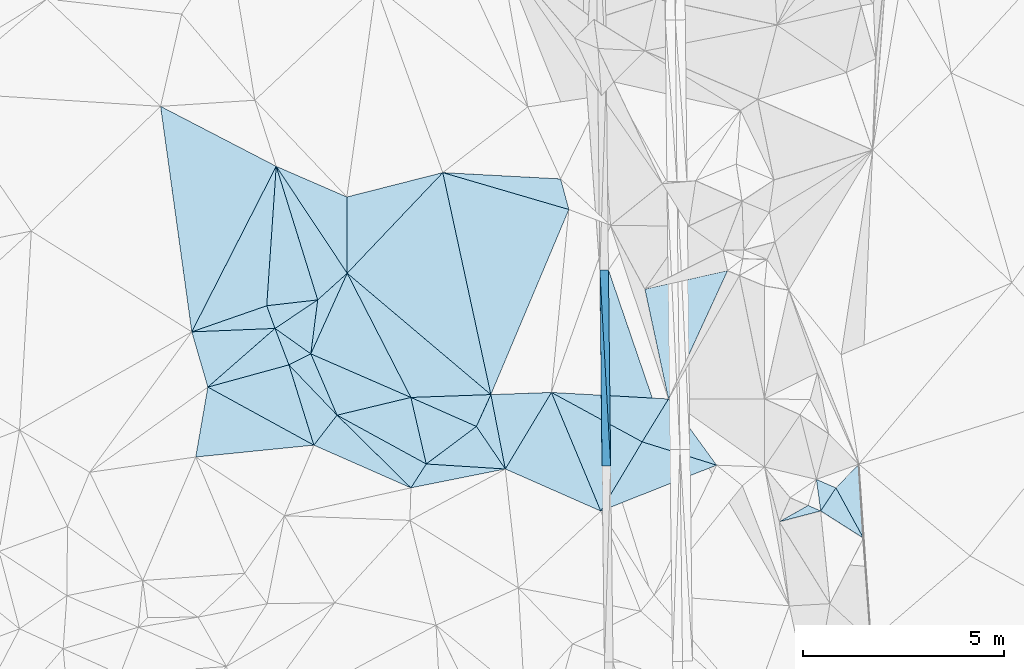
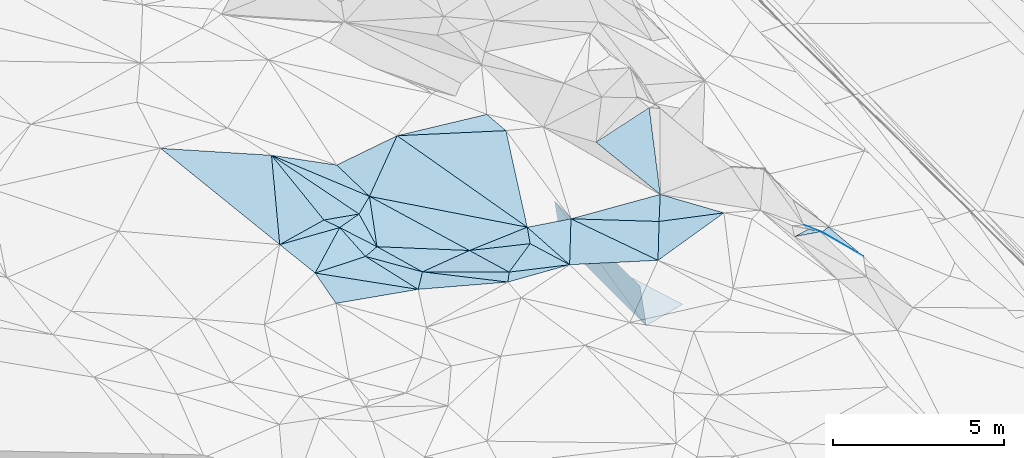
# One storey, part 13 of 275: 45 plates.
"""IFC2X3 building model written with IfcOpenShell, lengths in millimetres."""

from ifc_helpers import new_model, si_unit, frame, origin_with_axes, place, context, subcontext, project, spatial, polyline, outline, extrude, material, type_object, element, save


model = new_model("IFC2X3")

# Units and contexts
model_context = context("Model", 3, precision=1e-05, world=origin_with_axes())
body_context = subcontext(model_context, "Body", "Model", "MODEL_VIEW")
ifc_project = project(units=[si_unit("LENGTHUNIT", "METRE", prefix="MILLI"), si_unit("AREAUNIT", "SQUARE_METRE"), si_unit("VOLUMEUNIT", "CUBIC_METRE"), si_unit("MASSUNIT", "GRAM", prefix="KILO"), si_unit("TIMEUNIT", "SECOND"), si_unit("PLANEANGLEUNIT", "RADIAN"), si_unit("SOLIDANGLEUNIT", "STERADIAN"), si_unit("THERMODYNAMICTEMPERATUREUNIT", "DEGREE_CELSIUS"), si_unit("LUMINOUSINTENSITYUNIT", "LUMEN")], contexts=[model_context])

# Site, building, storey
site_placement = place(None, origin_with_axes())
site = spatial("IfcSite", under=ifc_project, at=site_placement, CompositionType="ELEMENT")
building_placement = place(site_placement, origin_with_axes())
building = spatial("IfcBuilding", under=site, at=building_placement, Name="Undefined", CompositionType="ELEMENT")
storey_placement = place(building_placement, origin_with_axes())
storey = spatial("IfcBuildingStorey", under=building, at=storey_placement, Name="Undefined", CompositionType="ELEMENT", Elevation=0.0)

# Plates
ifc_material = material()
plate_type_1 = type_object("IfcPlateType", PredefinedType="NOTDEFINED")
plate_1_placement = place(storey_placement, frame((-110130.239028706, 11119.0053173972, 45089.5004675806), z_axis=(0.0053338737207397, -0.0442314183425062, -0.999007072759018), x_axis=(-0.915008238746431, 0.402794931662664, -0.0227192881276)))
element("IfcPlate", 1, at=plate_1_placement, inside=storey, type_object=plate_type_1, material=ifc_material, Name="00", context=body_context, shape_type="SweptSolid", body=[
    extrude(outline(polyline([(0.0, 0.0), (2640.92797851563, 1.64291122928262e-08), (2414.45434570313, 917.065856933594), (0.0, 0.0)])), frame((-8.85201319254618e-08, 2.18876761149539e-07, -0.5000001331573), z_axis=(0.0, 0.0, 1.0), x_axis=(1.0, 0.0, 0.0)), (0.0, 0.0, 1.0), 1.0),
])
plate_type_2 = type_object("IfcPlateType", PredefinedType="NOTDEFINED")
plate_2_placement = place(storey_placement, frame((-105156.932146146, 11664.6181601126, 41451.6762923325), z_axis=(-0.9899146329082, -0.00833179240582941, -0.141419944808111), x_axis=(-0.141410880012788, -0.00167020099085582, 0.989949581262934)))
element("IfcPlate", 2, at=plate_2_placement, inside=storey, type_object=plate_type_2, material=ifc_material, Name="00_PR", context=body_context, shape_type="SweptSolid", body=[
    extrude(outline(polyline([(0.0, 0.0), (1515.22863769531, 2.66300048679113e-09), (1616.09216308594, 4885.20556640625), (0.0, 0.0)])), frame((-8.85201319254618e-08, 2.18876761149539e-07, -0.5000001331573), z_axis=(0.0, 0.0, 1.0), x_axis=(1.0, 0.0, 0.0)), (0.0, 0.0, 1.0), 1.0),
])
plate_3_placement = place(storey_placement, frame((-105426.912494542, 16546.9483812212, 43053.8472911902), z_axis=(-0.9899146329082, -0.00833179240582941, -0.141419944808111), x_axis=(0.141412524027666, 0.00155547700603329, -0.989949533329557)))
element("IfcPlate", 3, at=plate_3_placement, inside=storey, type_object=plate_type_2, material=ifc_material, Name="00_PR", context=body_context, shape_type="SweptSolid", body=[
    extrude(outline(polyline([(0.0, 0.0), (1515.22875976563, -2.92493496090174e-09), (1616.65270996094, 4885.0205078125), (0.0, 0.0)])), frame((-8.85201319254618e-08, 2.18876761149539e-07, -0.5000001331573), z_axis=(0.0, 0.0, 1.0), x_axis=(1.0, 0.0, 0.0)), (0.0, 0.0, 1.0), 1.0),
])
plate_type_3 = type_object("IfcPlateType", PredefinedType="NOTDEFINED")
plate_4_placement = place(storey_placement, frame((-105156.437303955, 11664.6327785077, 41451.2471111526), z_axis=(-0.000228104128301301, 0.0209094153861433, -0.999781348254065), x_axis=(-0.0114013891009877, 0.999716336142684, 0.0209106569963038)))
element("IfcPlate", 4, at=plate_4_placement, inside=storey, type_object=plate_type_3, material=ifc_material, Name="00_PR", context=body_context, shape_type="SweptSolid", body=[
    extrude(outline(polyline([(0.0, 0.0), (4886.0732421875, 1.48429535329342e-09), (393.802703857422, 1479.8544921875), (0.0, 0.0)])), frame((-8.85201319254618e-08, 2.18876761149539e-07, -0.5000001331573), z_axis=(0.0, 0.0, 1.0), x_axis=(1.0, 0.0, 0.0)), (0.0, 0.0, 1.0), 1.0),
])
plate_type_4 = type_object("IfcPlateType", PredefinedType="NOTDEFINED")
plate_5_placement = place(storey_placement, frame((-98862.6700222759, 9868.25020849909, 42819.6402361128), z_axis=(-0.674029591261077, -0.167293435981402, -0.719511651317726), x_axis=(-0.702389133978504, 0.446780994797911, 0.554108515686519)))
element("IfcPlate", 5, at=plate_5_placement, inside=storey, type_object=plate_type_4, material=ifc_material, Name="00", context=body_context, shape_type="SweptSolid", body=[
    extrude(outline(polyline([(0.0, 0.0), (1515.94860839844, -7.26140569895506e-09), (1232.89147949219, 795.7880859375), (0.0, 0.0)])), frame((-8.85201319254618e-08, 2.18876761149539e-07, -0.5000001331573), z_axis=(0.0, 0.0, 1.0), x_axis=(1.0, 0.0, 0.0)), (0.0, 0.0, 1.0), 1.0),
])
plate_type_5 = type_object("IfcPlateType", PredefinedType="NOTDEFINED")
plate_6_placement = place(storey_placement, frame((-106632.78345996, 13496.2431782016, 44679.5020463285), z_axis=(-0.0127394409879164, 0.0898641557380357, -0.99587255216559), x_axis=(0.998284841746694, -0.0557712403243994, -0.017802906826004)))
element("IfcPlate", 6, at=plate_6_placement, inside=storey, type_object=plate_type_5, material=ifc_material, Name="00", context=body_context, shape_type="SweptSolid", body=[
    extrude(outline(polyline([(0.0, 0.0), (2920.87133789063, 3.25962901115417e-09), (2328.06225585938, 1107.35107421875), (0.0, 0.0)])), frame((-8.85201319254618e-08, 2.18876761149539e-07, -0.5000001331573), z_axis=(0.0, 0.0, 1.0), x_axis=(1.0, 0.0, 0.0)), (0.0, 0.0, 1.0), 1.0),
])
plate_type_6 = type_object("IfcPlateType", PredefinedType="NOTDEFINED")
plate_7_placement = place(storey_placement, frame((-100033.494880504, 11329.5507361233, 43459.6153615499), z_axis=(-0.577058489481053, -0.274304851139707, -0.769259610508097), x_axis=(0.805127796024998, -0.349087637852481, -0.479486238766562)))
element("IfcPlate", 7, at=plate_7_placement, inside=storey, type_object=plate_type_6, material=ifc_material, Name="00", context=body_context, shape_type="SweptSolid", body=[
    extrude(outline(polyline([(0.0, 0.0), (604.814025878906, 2.53930920735002e-09), (263.221405029297, 772.472961425781), (0.0, 0.0)])), frame((-8.85201319254618e-08, 2.18876761149539e-07, -0.5000001331573), z_axis=(0.0, 0.0, 1.0), x_axis=(1.0, 0.0, 0.0)), (0.0, 0.0, 1.0), 1.0),
])
plate_type_7 = type_object("IfcPlateType", PredefinedType="NOTDEFINED")
plate_8_placement = place(storey_placement, frame((-115587.257552117, 15004.294891326, 45979.5018099799), z_axis=(-0.0805167497092928, -0.029362886133653, -0.996320668225925), x_axis=(0.940863941063242, 0.327767364665611, -0.0856948018674758)))
element("IfcPlate", 8, at=plate_8_placement, inside=storey, type_object=plate_type_7, material=ifc_material, Name="00", context=body_context, shape_type="SweptSolid", body=[
    extrude(outline(polyline([(0.0, 0.0), (1983.78430175781, -4.81668394058943e-09), (1992.45458984375, 601.269348144531), (0.0, 0.0)])), frame((-8.85201319254618e-08, 2.18876761149539e-07, -0.5000001331573), z_axis=(0.0, 0.0, 1.0), x_axis=(1.0, 0.0, 0.0)), (0.0, 0.0, 1.0), 1.0),
])
plate_type_8 = type_object("IfcPlateType", PredefinedType="NOTDEFINED")
plate_9_placement = place(storey_placement, frame((-112622.586519922, 14456.4102395896, 45199.5303135655), z_axis=(-0.250333388708989, 0.234567258158081, -0.939314322204061), x_axis=(0.123552824374264, 0.97001328402487, 0.209305825060913)))
element("IfcPlate", 9, at=plate_9_placement, inside=storey, type_object=plate_type_8, material=ifc_material, Name="00", context=body_context, shape_type="SweptSolid", body=[
    extrude(outline(polyline([(0.0, 0.0), (1385.53234863281, -6.98491930961609e-10), (2113.7001953125, 671.097412109375), (0.0, 0.0)])), frame((-8.85201319254618e-08, 2.18876761149539e-07, -0.5000001331573), z_axis=(0.0, 0.0, 1.0), x_axis=(1.0, 0.0, 0.0)), (0.0, 0.0, 1.0), 1.0),
])
plate_type_9 = type_object("IfcPlateType", PredefinedType="NOTDEFINED")
plate_10_placement = place(storey_placement, frame((-108499.612225928, 12648.9768326386, 44959.5011038815), z_axis=(0.0452481400221768, -0.0497726324744985, -0.997735080510399), x_axis=(-0.800536270796005, -0.599250012611244, -0.00641104714139014)))
element("IfcPlate", 10, at=plate_10_placement, inside=storey, type_object=plate_type_9, material=ifc_material, Name="00", context=body_context, shape_type="SweptSolid", body=[
    extrude(outline(polyline([(0.0, 0.0), (1559.80773925781, -7.7270669862628e-09), (873.889770507813, 1559.10766601563), (0.0, 0.0)])), frame((-8.85201319254618e-08, 2.18876761149539e-07, -0.5000001331573), z_axis=(0.0, 0.0, 1.0), x_axis=(1.0, 0.0, 0.0)), (0.0, 0.0, 1.0), 1.0),
])
plate_type_10 = type_object("IfcPlateType", PredefinedType="NOTDEFINED")
plate_11_placement = place(storey_placement, frame((-110130.873654558, 13371.0476788395, 44849.5010672645), z_axis=(0.0467587126944791, -0.0463743566773498, -0.997829164651904), x_axis=(0.998342954458697, 0.035710621637995, 0.0451231291568718)))
element("IfcPlate", 11, at=plate_11_placement, inside=storey, type_object=plate_type_10, material=ifc_material, Name="00", context=body_context, shape_type="SweptSolid", body=[
    extrude(outline(polyline([(0.0, 0.0), (1994.54260253906, 8.22183210402727e-09), (1607.73706054688, 780.821044921875), (0.0, 0.0)])), frame((-8.85201319254618e-08, 2.18876761149539e-07, -0.5000001331573), z_axis=(0.0, 0.0, 1.0), x_axis=(1.0, 0.0, 0.0)), (0.0, 0.0, 1.0), 1.0),
])
plate_type_11 = type_object("IfcPlateType", PredefinedType="NOTDEFINED")
plate_12_placement = place(storey_placement, frame((-99927.2867054487, 10545.6613474837, 43659.5299740237), z_axis=(-0.335644304558363, 0.0609418245336957, -0.940015422660734), x_axis=(-0.919000967652381, -0.24029571545601, 0.312562298730144)))
element("IfcPlate", 12, at=plate_12_placement, inside=storey, type_object=plate_type_11, material=ifc_material, Name="00", context=body_context, shape_type="SweptSolid", body=[
    extrude(outline(polyline([(0.0, 0.0), (1119.77673339844, -5.02041075378656e-10), (291.129455566406, 212.23486328125), (0.0, 0.0)])), frame((-8.85201319254618e-08, 2.18876761149539e-07, -0.5000001331573), z_axis=(0.0, 0.0, 1.0), x_axis=(1.0, 0.0, 0.0)), (0.0, 0.0, 1.0), 1.0),
])
plate_type_12 = type_object("IfcPlateType", PredefinedType="NOTDEFINED")
plate_13_placement = place(storey_placement, frame((-113484.522805138, 19126.6021320432, 45929.5059726855), z_axis=(-0.123731847321367, 0.0922621525188248, -0.988017269672466), x_axis=(0.547180286660819, -0.824272158770385, -0.145496192959792)))
element("IfcPlate", 13, at=plate_13_placement, inside=storey, type_object=plate_type_12, material=ifc_material, Name="00", context=body_context, shape_type="SweptSolid", body=[
    extrude(outline(polyline([(0.0, 0.0), (3230.32495117188, 1.02882040664554e-08), (3371.11596679688, 980.192810058594), (0.0, 0.0)])), frame((-8.85201319254618e-08, 2.18876761149539e-07, -0.5000001331573), z_axis=(0.0, 0.0, 1.0), x_axis=(1.0, 0.0, 0.0)), (0.0, 0.0, 1.0), 1.0),
])
plate_type_13 = type_object("IfcPlateType", PredefinedType="NOTDEFINED")
plate_14_placement = place(storey_placement, frame((-110130.332145329, 11118.9705848077, 45089.5115165396), z_axis=(-0.180895173490604, -0.113696509317189, -0.976908409205741), x_axis=(0.529735483545543, 0.825635214373268, -0.194182414908191)))
element("IfcPlate", 14, at=plate_14_placement, inside=storey, type_object=plate_type_13, material=ifc_material, Name="00", context=body_context, shape_type="SweptSolid", body=[
    extrude(outline(polyline([(0.0, 0.0), (720.971557617188, -6.83940015733242e-10), (1728.7783203125, 1731.30749511719), (0.0, 0.0)])), frame((-8.85201319254618e-08, 2.18876761149539e-07, -0.5000001331573), z_axis=(0.0, 0.0, 1.0), x_axis=(1.0, 0.0, 0.0)), (0.0, 0.0, 1.0), 1.0),
])
plate_type_14 = type_object("IfcPlateType", PredefinedType="NOTDEFINED")
plate_15_placement = place(storey_placement, frame((-108139.811785642, 13442.3544061412, 44939.5271730796), z_axis=(-0.304582367505653, 0.114371332071964, -0.945594405548561), x_axis=(0.187649738633346, -0.96610249559408, -0.17729507493929)))
element("IfcPlate", 15, at=plate_15_placement, inside=storey, type_object=plate_type_14, material=ifc_material, Name="00", context=body_context, shape_type="SweptSolid", body=[
    extrude(outline(polyline([(0.0, 0.0), (1917.70690917969, 3.78349795937538e-10), (695.3095703125, 525.209106445313), (0.0, 0.0)])), frame((-8.85201319254618e-08, 2.18876761149539e-07, -0.5000001331573), z_axis=(0.0, 0.0, 1.0), x_axis=(1.0, 0.0, 0.0)), (0.0, 0.0, 1.0), 1.0),
])
plate_type_15 = type_object("IfcPlateType", PredefinedType="NOTDEFINED")
plate_16_placement = place(storey_placement, frame((-103716.879033647, 13333.3795907513, 44627.5081008423), z_axis=(0.0731093649335433, 0.163920166040281, -0.983760743231982), x_axis=(-0.207550985586953, 0.967304723939105, 0.145753762994221)))
element("IfcPlate", 16, at=plate_16_placement, inside=storey, type_object=plate_type_15, material=ifc_material, Name="00", context=body_context, shape_type="SweptSolid", body=[
    extrude(outline(polyline([(0.0, 0.0), (2826.68505859375, 5.0058588385582e-09), (2879.75439453125, 2122.04711914063), (0.0, 0.0)])), frame((-8.85201319254618e-08, 2.18876761149539e-07, -0.5000001331573), z_axis=(0.0, 0.0, 1.0), x_axis=(1.0, 0.0, 0.0)), (0.0, 0.0, 1.0), 1.0),
])
plate_type_16 = type_object("IfcPlateType", PredefinedType="NOTDEFINED")
plate_17_placement = place(storey_placement, frame((-110130.931600381, 13371.1502482426, 44849.5075256331), z_axis=(-0.0691997048352708, 0.158765104317891, -0.984888340118635), x_axis=(-0.909299781669604, 0.396053272549244, 0.127732972871709)))
element("IfcPlate", 17, at=plate_17_placement, inside=storey, type_object=plate_type_16, material=ifc_material, Name="00", context=body_context, shape_type="SweptSolid", body=[
    extrude(outline(polyline([(0.0, 0.0), (2740.09130859375, -1.29839463625103e-08), (2744.98168945313, 2217.67358398438), (0.0, 0.0)])), frame((-8.85201319254618e-08, 2.18876761149539e-07, -0.5000001331573), z_axis=(0.0, 0.0, 1.0), x_axis=(1.0, 0.0, 0.0)), (0.0, 0.0, 1.0), 1.0),
])
plate_type_17 = type_object("IfcPlateType", PredefinedType="NOTDEFINED")
plate_18_placement = place(storey_placement, frame((-113168.300986216, 14182.2312605942, 45209.504219701), z_axis=(-0.119143806526544, 0.0522245732254987, -0.991502570504878), x_axis=(0.686473932212281, -0.717140332323045, -0.120263394882235)))
element("IfcPlate", 18, at=plate_18_placement, inside=storey, type_object=plate_type_17, material=ifc_material, Name="00", context=body_context, shape_type="SweptSolid", body=[
    extrude(outline(polyline([(0.0, 0.0), (1746.16723632813, 6.86850398778915e-09), (1882.17944335938, 934.773071289063), (0.0, 0.0)])), frame((-8.85201319254618e-08, 2.18876761149539e-07, -0.5000001331573), z_axis=(0.0, 0.0, 1.0), x_axis=(1.0, 0.0, 0.0)), (0.0, 0.0, 1.0), 1.0),
])
plate_type_18 = type_object("IfcPlateType", PredefinedType="NOTDEFINED")
plate_19_placement = place(storey_placement, frame((-111969.598025405, 12929.8780669997, 44999.5094965204), z_axis=(-0.109794282843866, -0.160265736480077, -0.980948576208406), x_axis=(0.877044101093676, -0.480004046352968, -0.0197423458981944)))
element("IfcPlate", 19, at=plate_19_placement, inside=storey, type_object=plate_type_18, material=ifc_material, Name="00", context=body_context, shape_type="SweptSolid", body=[
    extrude(outline(polyline([(0.0, 0.0), (2532.62719726563, 6.40284270048141e-09), (2480.62573242188, 719.09375), (0.0, 0.0)])), frame((-8.85201319254618e-08, 2.18876761149539e-07, -0.5000001331573), z_axis=(0.0, 0.0, 1.0), x_axis=(1.0, 0.0, 0.0)), (0.0, 0.0, 1.0), 1.0),
])
plate_type_19 = type_object("IfcPlateType", PredefinedType="NOTDEFINED")
plate_20_placement = place(storey_placement, frame((-111717.030725216, 16463.8807837561, 45459.5200463834), z_axis=(-0.279956253761397, -0.0164129730571429, -0.959872444804678), x_axis=(-0.547180286664111, 0.824272158766933, 0.145496192966969)))
element("IfcPlate", 20, at=plate_20_placement, inside=storey, type_object=plate_type_19, material=ifc_material, Name="00", context=body_context, shape_type="SweptSolid", body=[
    extrude(outline(polyline([(0.0, 0.0), (3230.32495117188, 1.02882040664554e-08), (1565.32238769531, 1075.11206054688), (0.0, 0.0)])), frame((-8.85201319254618e-08, 2.18876761149539e-07, -0.5000001331573), z_axis=(0.0, 0.0, 1.0), x_axis=(1.0, 0.0, 0.0)), (0.0, 0.0, 1.0), 1.0),
])
plate_type_20 = type_object("IfcPlateType", PredefinedType="NOTDEFINED")
plate_21_placement = place(storey_placement, frame((-112622.5861536, 14456.5259670229, 45199.5755408867), z_axis=(-0.249575017220913, 0.465998473601319, -0.848856721349618), x_axis=(-0.893521567279311, -0.448721722388903, 0.0163714587944975)))
element("IfcPlate", 21, at=plate_21_placement, inside=storey, type_object=plate_type_20, material=ifc_material, Name="00", context=body_context, shape_type="SweptSolid", body=[
    extrude(outline(polyline([(0.0, 0.0), (610.819091796875, -3.79804987460375e-09), (523.068115234375, 1138.2880859375), (0.0, 0.0)])), frame((-8.85201319254618e-08, 2.18876761149539e-07, -0.5000001331573), z_axis=(0.0, 0.0, 1.0), x_axis=(1.0, 0.0, 0.0)), (0.0, 0.0, 1.0), 1.0),
])
plate_type_21 = type_object("IfcPlateType", PredefinedType="NOTDEFINED")
plate_22_placement = place(storey_placement, frame((-111969.577505646, 12930.0085377947, 44999.5036971214), z_axis=(-0.0687336142612286, 0.100653844030535, -0.992544454396107), x_axis=(-0.686473932263594, 0.717140332281222, 0.120263394838734)))
element("IfcPlate", 22, at=plate_22_placement, inside=storey, type_object=plate_type_21, material=ifc_material, Name="00", context=body_context, shape_type="SweptSolid", body=[
    extrude(outline(polyline([(0.0, 0.0), (1746.16723632813, 6.86850398778915e-09), (1566.86022949219, 583.908386230469), (0.0, 0.0)])), frame((-8.85201319254618e-08, 2.18876761149539e-07, -0.5000001331573), z_axis=(0.0, 0.0, 1.0), x_axis=(1.0, 0.0, 0.0)), (0.0, 0.0, 1.0), 1.0),
])
plate_type_22 = type_object("IfcPlateType", PredefinedType="NOTDEFINED")
plate_23_placement = place(storey_placement, frame((-99546.5152060725, 11118.5309057799, 43169.5744541283), z_axis=(-0.522866332903249, -0.0477698405460068, -0.851075108466061), x_axis=(0.628355681953014, 0.653069813048333, -0.422692507908975)))
element("IfcPlate", 23, at=plate_23_placement, inside=storey, type_object=plate_type_22, material=ifc_material, Name="00", context=body_context, shape_type="SweptSolid", body=[
    extrude(outline(polyline([(0.0, 0.0), (906.096008300781, 2.2846506908536e-09), (-238.793670654297, 1447.85278320313), (0.0, 0.0)])), frame((-8.85201319254618e-08, 2.18876761149539e-07, -0.5000001331573), z_axis=(0.0, 0.0, 1.0), x_axis=(1.0, 0.0, 0.0)), (0.0, 0.0, 1.0), 1.0),
])
plate_type_23 = type_object("IfcPlateType", PredefinedType="NOTDEFINED")
plate_24_placement = place(storey_placement, frame((-109748.349112034, 11714.2496077405, 44949.5023719569), z_axis=(-0.0632736565364879, -0.0746790367919436, -0.995198214353467), x_axis=(-0.877044101093404, 0.48000404635359, 0.0197423458951636)))
element("IfcPlate", 24, at=plate_24_placement, inside=storey, type_object=plate_type_23, material=ifc_material, Name="00", context=body_context, shape_type="SweptSolid", body=[
    extrude(outline(polyline([(0.0, 0.0), (2532.62719726563, 6.40284270048141e-09), (1128.82788085938, 1275.55773925781), (0.0, 0.0)])), frame((-8.85201319254618e-08, 2.18876761149539e-07, -0.5000001331573), z_axis=(0.0, 0.0, 1.0), x_axis=(1.0, 0.0, 0.0)), (0.0, 0.0, 1.0), 1.0),
])
plate_type_24 = type_object("IfcPlateType", PredefinedType="NOTDEFINED")
plate_25_placement = place(storey_placement, frame((-107779.880887842, 11589.7058929191, 44599.5186315062), z_axis=(-0.157207866845458, 0.220312670323401, -0.962677523315504), x_axis=(-0.982649827128658, 0.0622437703366048, 0.174714138804802)))
element("IfcPlate", 25, at=plate_25_placement, inside=storey, type_object=plate_type_24, material=ifc_material, Name="00", context=body_context, shape_type="SweptSolid", body=[
    extrude(outline(polyline([(0.0, 0.0), (2003.27233886719, -3.69982444681227e-09), (836.181884765625, 1034.84289550781), (0.0, 0.0)])), frame((-8.85201319254618e-08, 2.18876761149539e-07, -0.5000001331573), z_axis=(0.0, 0.0, 1.0), x_axis=(1.0, 0.0, 0.0)), (0.0, 0.0, 1.0), 1.0),
])
plate_type_25 = type_object("IfcPlateType", PredefinedType="NOTDEFINED")
plate_26_placement = place(storey_placement, frame((-105402.899296133, 10541.1450281113, 44559.5000116017), z_axis=(0.00148521485448212, -0.0124876481131361, -0.999920923264154), x_axis=(0.513179992709505, 0.858223267705273, -0.00995579489317697)))
element("IfcPlate", 26, at=plate_26_placement, inside=storey, type_object=plate_type_25, material=ifc_material, Name="00", context=body_context, shape_type="SweptSolid", body=[
    extrude(outline(polyline([(0.0, 0.0), (2008.88024902344, 1.17870513349772e-09), (2461.5703125, 1888.16625976563), (0.0, 0.0)])), frame((-8.85201319254618e-08, 2.18876761149539e-07, -0.5000001331573), z_axis=(0.0, 0.0, 1.0), x_axis=(1.0, 0.0, 0.0)), (0.0, 0.0, 1.0), 1.0),
])
plate_type_26 = type_object("IfcPlateType", PredefinedType="NOTDEFINED")
plate_27_placement = place(storey_placement, frame((-106197.409997489, 18051.325735319, 44909.5139481677), z_axis=(-0.0439824867547819, 0.230536031010772, -0.972069276988356), x_axis=(-0.953976055647414, 0.279221783490777, 0.109384097910213)))
element("IfcPlate", 27, at=plate_27_placement, inside=storey, type_object=plate_type_26, material=ifc_material, Name="00", context=body_context, shape_type="SweptSolid", body=[
    extrude(outline(polyline([(0.0, 0.0), (3291.15478515625, -1.19707692647353e-08), (429.697204589844, 688.665588378906), (0.0, 0.0)])), frame((-8.85201319254618e-08, 2.18876761149539e-07, -0.5000001331573), z_axis=(0.0, 0.0, 1.0), x_axis=(1.0, 0.0, 0.0)), (0.0, 0.0, 1.0), 1.0),
])
plate_type_27 = type_object("IfcPlateType", PredefinedType="NOTDEFINED")
plate_28_placement = place(storey_placement, frame((-113484.513416906, 19126.5767426272, 45929.5031764084), z_axis=(-0.10495066669899, 0.0414834719392436, -0.993611835233107), x_axis=(-0.0678566303623436, -0.997099728443226, -0.0344617070719512)))
element("IfcPlate", 28, at=plate_28_placement, inside=storey, type_object=plate_type_27, material=ifc_material, Name="00", context=body_context, shape_type="SweptSolid", body=[
    extrude(outline(polyline([(0.0, 0.0), (3482.12573242188, 1.73167791217566e-09), (4251.25341796875, 1828.61755371094), (0.0, 0.0)])), frame((-8.85201319254618e-08, 2.18876761149539e-07, -0.5000001331573), z_axis=(0.0, 0.0, 1.0), x_axis=(1.0, 0.0, 0.0)), (0.0, 0.0, 1.0), 1.0),
])
plate_type_28 = type_object("IfcPlateType", PredefinedType="NOTDEFINED")
plate_29_placement = place(storey_placement, frame((-113168.395731425, 14182.4250785714, 45209.5782758299), z_axis=(-0.308611633384999, 0.439838454301592, -0.843386621815303), x_axis=(-0.942861854343535, -0.258517527771771, 0.210190892901292)))
element("IfcPlate", 29, at=plate_29_placement, inside=storey, type_object=plate_type_28, material=ifc_material, Name="00", context=body_context, shape_type="SweptSolid", body=[
    extrude(outline(polyline([(0.0, 0.0), (2140.9111328125, -1.47847458720207e-08), (218.224853515625, 1120.61499023438), (0.0, 0.0)])), frame((-8.85201319254618e-08, 2.18876761149539e-07, -0.5000001331573), z_axis=(0.0, 0.0, 1.0), x_axis=(1.0, 0.0, 0.0)), (0.0, 0.0, 1.0), 1.0),
])
plate_type_29 = type_object("IfcPlateType", PredefinedType="NOTDEFINED")
plate_30_placement = place(storey_placement, frame((-113514.841505664, 15089.5485618622, 45809.5157680414), z_axis=(-0.234298679486281, -0.085444153247335, -0.968402512113032), x_axis=(-0.342609275698453, 0.939477984949824, -4.40430446013285e-11)))
element("IfcPlate", 30, at=plate_30_placement, inside=storey, type_object=plate_type_29, material=ifc_material, Name="00", context=body_context, shape_type="SweptSolid", body=[
    extrude(outline(polyline([(0.0, 0.0), (601.331848144531, -1.67347025126219e-09), (303.326690673828, 1283.11840820313), (0.0, 0.0)])), frame((-8.85201319254618e-08, 2.18876761149539e-07, -0.5000001331573), z_axis=(0.0, 0.0, 1.0), x_axis=(1.0, 0.0, 0.0)), (0.0, 0.0, 1.0), 1.0),
])
plate_type_30 = type_object("IfcPlateType", PredefinedType="NOTDEFINED")
plate_31_placement = place(storey_placement, frame((-111969.593930894, 12930.0014152148, 44999.5044356403), z_axis=(-0.10158335845845, 0.0864081999180268, -0.991067325801445), x_axis=(-0.390472280595414, 0.912811725633841, 0.119608325930875)))
element("IfcPlate", 31, at=plate_31_placement, inside=storey, type_object=plate_type_30, material=ifc_material, Name="00", context=body_context, shape_type="SweptSolid", body=[
    extrude(outline(polyline([(0.0, 0.0), (1672.12438964844, 3.49245965480804e-09), (-333.228790283203, 1867.25964355469), (0.0, 0.0)])), frame((-8.85201319254618e-08, 2.18876761149539e-07, -0.5000001331573), z_axis=(0.0, 0.0, 1.0), x_axis=(1.0, 0.0, 0.0)), (0.0, 0.0, 1.0), 1.0),
])
plate_type_31 = type_object("IfcPlateType", PredefinedType="NOTDEFINED")
plate_32_placement = place(storey_placement, frame((-112546.829557856, 12182.7777651706, 45029.5138815099), z_axis=(-0.234208362689234, -0.0040556124436549, -0.972177964600173), x_axis=(-0.967515355474737, -0.0969365826542579, 0.233489476987522)))
element("IfcPlate", 32, at=plate_32_placement, inside=storey, type_object=plate_type_31, material=ifc_material, Name="00", context=body_context, shape_type="SweptSolid", body=[
    extrude(outline(polyline([(0.0, 0.0), (3040.822265625, 5.01313479617238e-09), (2561.28100585938, 1702.27502441406), (0.0, 0.0)])), frame((-8.85201319254618e-08, 2.18876761149539e-07, -0.5000001331573), z_axis=(0.0, 0.0, 1.0), x_axis=(1.0, 0.0, 0.0)), (0.0, 0.0, 1.0), 1.0),
])
plate_type_32 = type_object("IfcPlateType", PredefinedType="NOTDEFINED")
plate_33_placement = place(storey_placement, frame((-112451.487140253, 15800.3989351498, 45489.5637588254), z_axis=(-0.424452535732472, 0.242312031344444, -0.872424738516741), x_axis=(-0.123552824372258, -0.970013284029159, -0.209305825042218)))
element("IfcPlate", 33, at=plate_33_placement, inside=storey, type_object=plate_type_32, material=ifc_material, Name="00", context=body_context, shape_type="SweptSolid", body=[
    extrude(outline(polyline([(0.0, 0.0), (1385.53234863281, -6.98491930961609e-10), (753.789672851563, 1081.75830078125), (0.0, 0.0)])), frame((-8.85201319254618e-08, 2.18876761149539e-07, -0.5000001331573), z_axis=(0.0, 0.0, 1.0), x_axis=(1.0, 0.0, 0.0)), (0.0, 0.0, 1.0), 1.0),
])
plate_type_33 = type_object("IfcPlateType", PredefinedType="NOTDEFINED")
plate_34_placement = place(storey_placement, frame((-106632.802746892, 13496.2078111754, 44679.500724787), z_axis=(-0.0514029142026939, 0.0191536902003394, -0.998494304722456), x_axis=(0.876955568466603, -0.477493280552253, -0.0543055978962015)))
element("IfcPlate", 34, at=plate_34_placement, inside=storey, type_object=plate_type_33, material=ifc_material, Name="00", context=body_context, shape_type="SweptSolid", body=[
    extrude(outline(polyline([(0.0, 0.0), (2578.00317382813, 8.41100700199604e-09), (2496.07934570313, 2007.20910644531), (0.0, 0.0)])), frame((-8.85201319254618e-08, 2.18876761149539e-07, -0.5000001331573), z_axis=(0.0, 0.0, 1.0), x_axis=(1.0, 0.0, 0.0)), (0.0, 0.0, 1.0), 1.0),
])
plate_type_34 = type_object("IfcPlateType", PredefinedType="NOTDEFINED")
plate_35_placement = place(storey_placement, frame((-108139.74611625, 13442.3697656114, 44939.5129090168), z_axis=(-0.173267904550511, 0.145112940662206, -0.974125488684616), x_axis=(0.984827378270407, 0.035227170618373, -0.169923751898496)))
element("IfcPlate", 35, at=plate_35_placement, inside=storey, type_object=plate_type_34, material=ifc_material, Name="00", context=body_context, shape_type="SweptSolid", body=[
    extrude(outline(polyline([(0.0, 0.0), (1530.09802246094, -8.32733348943293e-09), (346.905883789063, 1886.06896972656), (0.0, 0.0)])), frame((-8.85201319254618e-08, 2.18876761149539e-07, -0.5000001331573), z_axis=(0.0, 0.0, 1.0), x_axis=(1.0, 0.0, 0.0)), (0.0, 0.0, 1.0), 1.0),
])
plate_type_35 = type_object("IfcPlateType", PredefinedType="NOTDEFINED")
plate_36_placement = place(storey_placement, frame((-115587.267547089, 15004.3291777545, 45979.5028886391), z_axis=(-0.100503463961403, 0.0392082605531012, -0.994163852710487), x_axis=(-0.136852615656662, 0.989180769235302, 0.0528466400349679)))
element("IfcPlate", 36, at=plate_36_placement, inside=storey, type_object=plate_type_35, material=ifc_material, Name="00", context=body_context, shape_type="SweptSolid", body=[
    extrude(outline(polyline([(0.0, 0.0), (5676.8037109375, -4.10364009439945e-09), (3787.23681640625, 2659.66870117188), (0.0, 0.0)])), frame((-8.85201319254618e-08, 2.18876761149539e-07, -0.5000001331573), z_axis=(0.0, 0.0, 1.0), x_axis=(1.0, 0.0, 0.0)), (0.0, 0.0, 1.0), 1.0),
])
plate_type_36 = type_object("IfcPlateType", PredefinedType="NOTDEFINED")
plate_37_placement = place(storey_placement, frame((-111716.872406987, 16463.9946779926, 45459.5116134865), z_axis=(0.0365838762462334, 0.211398768475751, -0.976714994604739), x_axis=(0.759276347029387, -0.641340473212196, -0.110371310863231)))
element("IfcPlate", 37, at=plate_37_placement, inside=storey, type_object=plate_type_36, material=ifc_material, Name="00", context=body_context, shape_type="SweptSolid", body=[
    extrude(outline(polyline([(0.0, 0.0), (4711.369140625, -2.38505890592933e-08), (3255.08349609375, 1362.87622070313), (0.0, 0.0)])), frame((-8.85201319254618e-08, 2.18876761149539e-07, -0.5000001331573), z_axis=(0.0, 0.0, 1.0), x_axis=(1.0, 0.0, 0.0)), (0.0, 0.0, 1.0), 1.0),
])
plate_type_37 = type_object("IfcPlateType", PredefinedType="NOTDEFINED")
plate_38_placement = place(storey_placement, frame((-112546.823657631, 12182.789102246, 45029.5125830727), z_axis=(-0.222410091414022, 0.018617980628668, -0.974775421332789), x_axis=(-0.858469837856465, 0.470175094214275, 0.204853406784687)))
element("IfcPlate", 38, at=plate_38_placement, inside=storey, type_object=plate_type_37, material=ifc_material, Name="00", context=body_context, shape_type="SweptSolid", body=[
    extrude(outline(polyline([(0.0, 0.0), (3075.36987304688, -3.10683390125632e-09), (1510.51745605469, 1461.07385253906), (0.0, 0.0)])), frame((-8.85201319254618e-08, 2.18876761149539e-07, -0.5000001331573), z_axis=(0.0, 0.0, 1.0), x_axis=(1.0, 0.0, 0.0)), (0.0, 0.0, 1.0), 1.0),
])
plate_type_38 = type_object("IfcPlateType", PredefinedType="NOTDEFINED")
plate_39_placement = place(storey_placement, frame((-113514.768495982, 15089.6918936798, 45809.5121938263), z_axis=(-0.0883025007781734, 0.20124162709311, -0.975553420311383), x_axis=(-0.751363527685793, -0.656437117540321, -0.0674029671373316)))
element("IfcPlate", 39, at=plate_39_placement, inside=storey, type_object=plate_type_38, material=ifc_material, Name="00", context=body_context, shape_type="SweptSolid", body=[
    extrude(outline(polyline([(0.0, 0.0), (2225.42138671875, 1.1146767064929e-08), (1601.71923828125, 1328.8701171875), (0.0, 0.0)])), frame((-8.85201319254618e-08, 2.18876761149539e-07, -0.5000001331573), z_axis=(0.0, 0.0, 1.0), x_axis=(1.0, 0.0, 0.0)), (0.0, 0.0, 1.0), 1.0),
])
plate_type_39 = type_object("IfcPlateType", PredefinedType="NOTDEFINED")
plate_40_placement = place(storey_placement, frame((-105402.899374469, 10541.1718344046, 44559.5003949131), z_axis=(0.00132620836949599, 0.0411260613226531, -0.999153085493633), x_axis=(-0.914836214289365, 0.403531512458827, 0.01539543690174)))
element("IfcPlate", 40, at=plate_40_placement, inside=storey, type_object=plate_type_39, material=ifc_material, Name="00", context=body_context, shape_type="SweptSolid", body=[
    extrude(outline(polyline([(0.0, 0.0), (2598.17236328125, -6.96672941558063e-09), (2319.43798828125, 2208.96069335938), (0.0, 0.0)])), frame((-8.85201319254618e-08, 2.18876761149539e-07, -0.5000001331573), z_axis=(0.0, 0.0, 1.0), x_axis=(1.0, 0.0, 0.0)), (0.0, 0.0, 1.0), 1.0),
])
plate_type_40 = type_object("IfcPlateType", PredefinedType="NOTDEFINED")
plate_41_placement = place(storey_placement, frame((-104371.969859371, 12265.252171208, 44539.5012493066), z_axis=(0.0261086973036127, 0.0661694036897203, -0.997466764328745), x_axis=(0.521531752344659, 0.850350552205634, 0.0700611851161673)))
element("IfcPlate", 41, at=plate_41_placement, inside=storey, type_object=plate_type_40, material=ifc_material, Name="00", context=body_context, shape_type="SweptSolid", body=[
    extrude(outline(polyline([(0.0, 0.0), (1256.04504394531, 2.56113708019257e-09), (473.533996582031, 1883.046875), (0.0, 0.0)])), frame((-8.85201319254618e-08, 2.18876761149539e-07, -0.5000001331573), z_axis=(0.0, 0.0, 1.0), x_axis=(1.0, 0.0, 0.0)), (0.0, 0.0, 1.0), 1.0),
])
plate_type_41 = type_object("IfcPlateType", PredefinedType="NOTDEFINED")
plate_42_placement = place(storey_placement, frame((-108139.711102135, 13442.3157184357, 44939.5029934789), z_axis=(-0.103142367462433, 0.0369959517025035, -0.993978345635291), x_axis=(-0.211344125711488, 0.975674714116017, 0.0582452810266689)))
element("IfcPlate", 42, at=plate_42_placement, inside=storey, type_object=plate_type_41, material=ifc_material, Name="00", context=body_context, shape_type="SweptSolid", body=[
    extrude(outline(polyline([(0.0, 0.0), (5665.69482421875, 7.84348230808973e-09), (4084.56518554688, 2886.47338867188), (0.0, 0.0)])), frame((-8.85201319254618e-08, 2.18876761149539e-07, -0.5000001331573), z_axis=(0.0, 0.0, 1.0), x_axis=(1.0, 0.0, 0.0)), (0.0, 0.0, 1.0), 1.0),
])
plate_type_42 = type_object("IfcPlateType", PredefinedType="NOTDEFINED")
plate_43_placement = place(storey_placement, frame((-112451.399737625, 15800.3029933657, 45489.5164582497), z_axis=(-0.249554280752043, 0.0504062299521432, -0.967048019976434), x_axis=(-0.963713888254783, -0.110644345682726, 0.242926676907434)))
element("IfcPlate", 43, at=plate_43_placement, inside=storey, type_object=plate_type_42, material=ifc_material, Name="00", context=body_context, shape_type="SweptSolid", body=[
    extrude(outline(polyline([(0.0, 0.0), (1317.26989746094, -7.72342900745571e-09), (734.549560546875, 3433.021484375), (0.0, 0.0)])), frame((-8.85201319254618e-08, 2.18876761149539e-07, -0.5000001331573), z_axis=(0.0, 0.0, 1.0), x_axis=(1.0, 0.0, 0.0)), (0.0, 0.0, 1.0), 1.0),
])
plate_type_43 = type_object("IfcPlateType", PredefinedType="NOTDEFINED")
plate_44_placement = place(storey_placement, frame((-111716.922130166, 16463.8809669678, 45459.5010328009), z_axis=(-0.0627710123519839, -0.0160465080188425, -0.997898947583726), x_axis=(-0.00445315165903609, 0.999865287087078, -0.0157980099562012)))
element("IfcPlate", 44, at=plate_44_placement, inside=storey, type_object=plate_type_43, material=ifc_material, Name="00", context=body_context, shape_type="SweptSolid", body=[
    extrude(outline(polyline([(0.0, 0.0), (1898.97338867188, -2.13913153856993e-09), (2498.34985351563, 2395.69360351563), (0.0, 0.0)])), frame((-8.85201319254618e-08, 2.18876761149539e-07, -0.5000001331573), z_axis=(0.0, 0.0, 1.0), x_axis=(1.0, 0.0, 0.0)), (0.0, 0.0, 1.0), 1.0),
])
plate_type_44 = type_object("IfcPlateType", PredefinedType="NOTDEFINED")
plate_45_placement = place(storey_placement, frame((-108139.717226045, 13442.3143585898, 44939.5036129222), z_axis=(-0.115355312204705, 0.034276106156159, -0.992732743739687), x_axis=(-0.759276347006165, 0.641340473250347, 0.110371310801294)))
element("IfcPlate", 45, at=plate_45_placement, inside=storey, type_object=plate_type_44, material=ifc_material, Name="00", context=body_context, shape_type="SweptSolid", body=[
    extrude(outline(polyline([(0.0, 0.0), (4711.369140625, -2.38505890592933e-08), (4490.8388671875, 3454.34033203125), (0.0, 0.0)])), frame((-8.85201319254618e-08, 2.18876761149539e-07, -0.5000001331573), z_axis=(0.0, 0.0, 1.0), x_axis=(1.0, 0.0, 0.0)), (0.0, 0.0, 1.0), 1.0),
])

save(model, "model.ifc")
